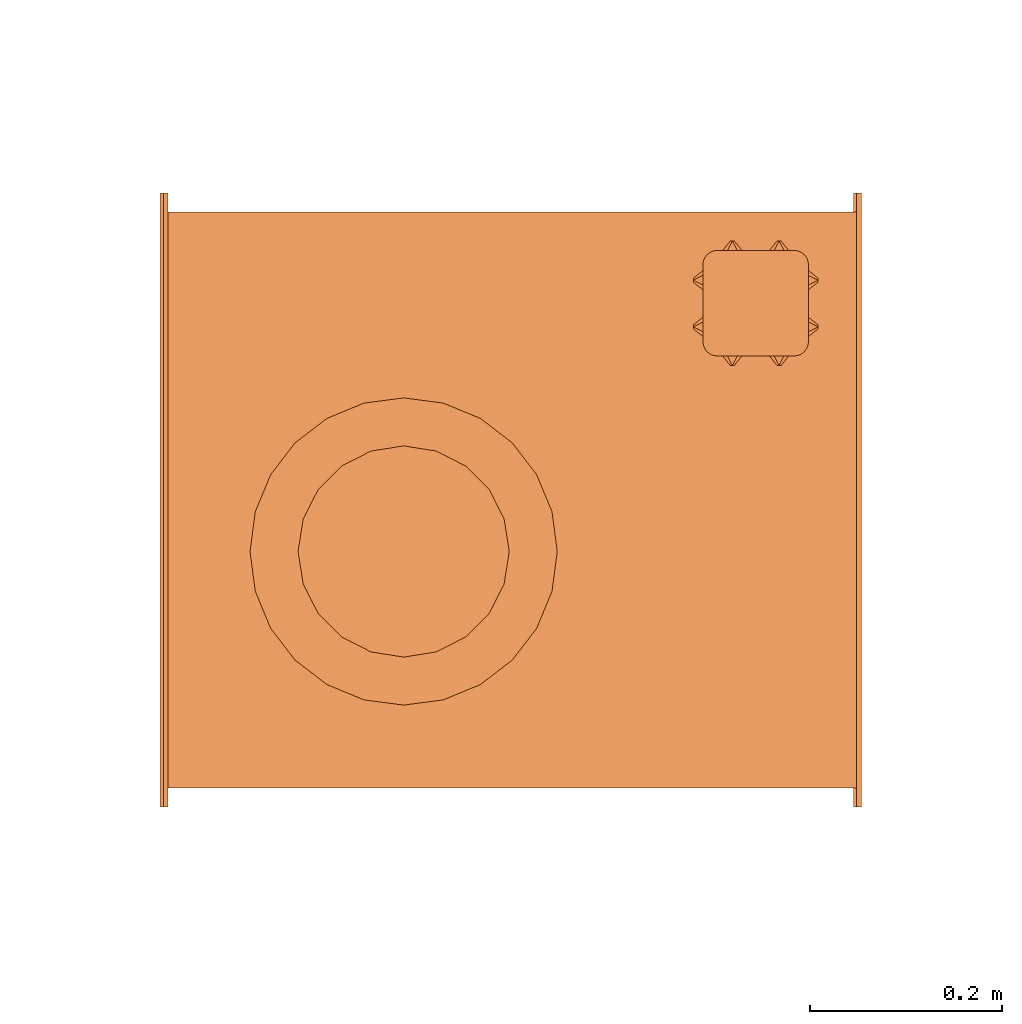
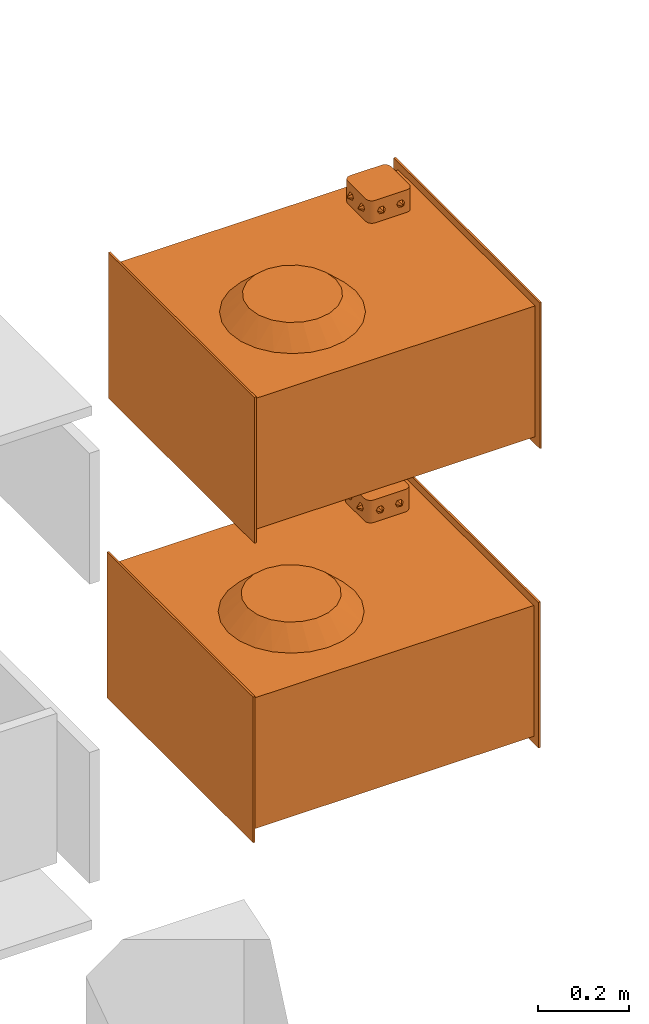
# One storey, part 44 of 44: 2 proxies.
"""IFC2X3 building model written with IfcOpenShell, lengths in millimetres."""

from ifc_helpers import new_model, entity, si_unit, converted_unit, derived_unit, direction, frame, origin, place, context, subcontext, project, spatial, faceted_brep, source, transform, mapped, material, material_list, type_object, type_shapes, element, save


model = new_model("IFC2X3")

# Units and contexts
model_context = context("Model", 3, precision=0.01, world=origin(), true_north=direction((6.12303176911189e-17, 1.0)))
body_context = subcontext(model_context, "Body", "Model", "MODEL_VIEW")
ifc_project = project(units=[si_unit("LENGTHUNIT", "METRE", prefix="MILLI"), si_unit("AREAUNIT", "SQUARE_METRE"), si_unit("VOLUMEUNIT", "CUBIC_METRE"), converted_unit("PLANEANGLEUNIT", "DEGREE", entity("IfcRatioMeasure", 0.0174532925199433), si_unit("PLANEANGLEUNIT", "RADIAN"), dimensions=[0, 0, 0, 0, 0, 0, 0]), si_unit("MASSUNIT", "GRAM", prefix="KILO"), derived_unit("MASSDENSITYUNIT", [(si_unit("MASSUNIT", "GRAM", prefix="KILO"), 1), (si_unit("LENGTHUNIT", "METRE"), -3)]), derived_unit("MOMENTOFINERTIAUNIT", [(si_unit("LENGTHUNIT", "METRE"), 4)]), si_unit("TIMEUNIT", "SECOND"), si_unit("FREQUENCYUNIT", "HERTZ"), si_unit("THERMODYNAMICTEMPERATUREUNIT", "DEGREE_CELSIUS"), derived_unit("THERMALTRANSMITTANCEUNIT", [(si_unit("MASSUNIT", "GRAM", prefix="KILO"), 1), (si_unit("THERMODYNAMICTEMPERATUREUNIT", "KELVIN"), -1), (si_unit("TIMEUNIT", "SECOND"), -3)]), derived_unit("VOLUMETRICFLOWRATEUNIT", [(si_unit("LENGTHUNIT", "METRE"), 3), (si_unit("TIMEUNIT", "SECOND"), -1)]), derived_unit("MASSFLOWRATEUNIT", [(si_unit("MASSUNIT", "GRAM", prefix="KILO"), 1), (si_unit("TIMEUNIT", "SECOND"), -1)]), derived_unit("ROTATIONALFREQUENCYUNIT", [(si_unit("TIMEUNIT", "SECOND"), -1)]), si_unit("ELECTRICCURRENTUNIT", "AMPERE"), si_unit("ELECTRICVOLTAGEUNIT", "VOLT"), si_unit("POWERUNIT", "WATT"), si_unit("FORCEUNIT", "NEWTON", prefix="KILO"), si_unit("ILLUMINANCEUNIT", "LUX"), si_unit("LUMINOUSFLUXUNIT", "LUMEN"), si_unit("LUMINOUSINTENSITYUNIT", "CANDELA"), derived_unit("USERDEFINED", [(si_unit("MASSUNIT", "GRAM", prefix="KILO"), -1), (si_unit("LENGTHUNIT", "METRE"), -2), (si_unit("TIMEUNIT", "SECOND"), 3), (si_unit("LUMINOUSFLUXUNIT", "LUMEN"), 1)]), derived_unit("LINEARVELOCITYUNIT", [(si_unit("LENGTHUNIT", "METRE"), 1), (si_unit("TIMEUNIT", "SECOND"), -1)]), si_unit("PRESSUREUNIT", "PASCAL"), derived_unit("USERDEFINED", [(si_unit("LENGTHUNIT", "METRE"), -2), (si_unit("MASSUNIT", "GRAM", prefix="KILO"), 1), (si_unit("TIMEUNIT", "SECOND"), -2)]), derived_unit("LINEARFORCEUNIT", [(si_unit("MASSUNIT", "GRAM", prefix="KILO"), 1), (si_unit("LENGTHUNIT", "METRE"), 1), (si_unit("TIMEUNIT", "SECOND"), -2), (si_unit("LENGTHUNIT", "METRE"), -1)]), derived_unit("PLANARFORCEUNIT", [(si_unit("MASSUNIT", "GRAM", prefix="KILO"), 1), (si_unit("LENGTHUNIT", "METRE"), 1), (si_unit("TIMEUNIT", "SECOND"), -2), (si_unit("LENGTHUNIT", "METRE"), -2)])], contexts=[model_context])

# Site, building, storey
site_placement = place(None, origin())
site = spatial("IfcSite", under=ifc_project, at=site_placement, CompositionType="ELEMENT")
building_placement = place(site_placement, origin())
building = spatial("IfcBuilding", under=site, at=building_placement, CompositionType="ELEMENT")
storey_placement = place(building_placement, frame((0.0, 0.0, 15900.0)))
storey = spatial("IfcBuildingStorey", under=building, at=storey_placement, CompositionType="ELEMENT", Elevation=15900.0)

# Proxies
ifc_material_1 = material()
ifc_material_2 = material()
ifc_material_list_1 = material_list([ifc_material_1, ifc_material_2])
ifc_material_3 = material()
ifc_material_list_2 = material_list([ifc_material_2, ifc_material_3, ifc_material_1])
building_element_proxy_type = type_object("IfcBuildingElementProxyType", PredefinedType="NOTDEFINED", material=ifc_material_list_2)
shared_shape = source(origin(), body_context, "Body", "Brep", [
    faceted_brep([(-188.5, -182.29, 203.93), (-188.5, -180.29, 201.93), (-188.5, -178.29, 203.93), (-188.5, -180.29, 205.93), (-198.5, -175.29, 195.27), (-198.5, -185.29, 195.27), (-198.5, -190.29, 203.93), (-198.5, -185.29, 212.59), (-198.5, -175.29, 212.59), (-198.5, -170.29, 203.93)], [[[0, 1, 2, 3]], [[4, 5, 6, 7, 8, 9]], [[2, 4, 9]], [[4, 2, 1]], [[1, 0, 5]], [[6, 5, 0]], [[1, 5, 4]], [[0, 7, 6]], [[7, 0, 3]], [[3, 2, 8]], [[9, 8, 2]], [[3, 8, 7]]]),
    faceted_brep([(-188.5, -226.95, 203.93), (-188.5, -228.95, 205.93), (-188.5, -230.95, 203.93), (-188.5, -228.95, 201.93), (-198.5, -223.95, 212.59), (-198.5, -218.95, 203.93), (-198.5, -223.95, 195.27), (-198.5, -233.95, 195.27), (-198.5, -238.95, 203.93), (-198.5, -233.95, 212.59)], [[[0, 1, 2, 3]], [[4, 5, 6, 7, 8, 9]], [[0, 6, 5]], [[6, 0, 3]], [[3, 2, 7]], [[8, 7, 2]], [[3, 7, 6]], [[2, 9, 8]], [[9, 2, 1]], [[1, 0, 4]], [[5, 4, 0]], [[1, 4, 9]]]),
    faceted_brep([(-318.5, -182.29, 203.93), (-318.5, -180.29, 205.93), (-318.5, -178.29, 203.93), (-318.5, -180.29, 201.93), (-308.5, -185.29, 212.59), (-308.5, -190.29, 203.93), (-308.5, -185.29, 195.27), (-308.5, -175.29, 195.27), (-308.5, -170.29, 203.93), (-308.5, -175.29, 212.59)], [[[0, 1, 2, 3]], [[4, 5, 6, 7, 8, 9]], [[0, 6, 5]], [[6, 0, 3]], [[3, 2, 7]], [[8, 7, 2]], [[3, 7, 6]], [[2, 9, 8]], [[9, 2, 1]], [[1, 0, 4]], [[5, 4, 0]], [[1, 4, 9]]]),
    faceted_brep([(-318.5, -226.95, 203.93), (-318.5, -228.95, 201.93), (-318.5, -230.95, 203.93), (-318.5, -228.95, 205.93), (-308.5, -233.95, 195.27), (-308.5, -223.95, 195.27), (-308.5, -218.95, 203.93), (-308.5, -223.95, 212.59), (-308.5, -233.95, 212.59), (-308.5, -238.95, 203.93)], [[[0, 1, 2, 3]], [[4, 5, 6, 7, 8, 9]], [[2, 4, 9]], [[4, 2, 1]], [[1, 0, 5]], [[6, 5, 0]], [[1, 5, 4]], [[0, 7, 6]], [[7, 0, 3]], [[3, 2, 8]], [[9, 8, 2]], [[3, 8, 7]]]),
    faceted_brep([(-231.17, -140.0, 203.93), (-229.17, -140.0, 205.93), (-227.17, -140.0, 203.93), (-229.17, -140.0, 201.93), (-234.17, -150.0, 212.59), (-239.17, -150.0, 203.93), (-234.17, -150.0, 195.27), (-224.17, -150.0, 195.27), (-219.17, -150.0, 203.93), (-224.17, -150.0, 212.59)], [[[0, 1, 2, 3]], [[4, 5, 6, 7, 8, 9]], [[0, 6, 5]], [[6, 0, 3]], [[3, 2, 7]], [[8, 7, 2]], [[3, 7, 6]], [[2, 9, 8]], [[9, 2, 1]], [[1, 0, 4]], [[5, 4, 0]], [[1, 4, 9]]]),
    faceted_brep([(-275.83, -140.0, 203.93), (-277.83, -140.0, 201.93), (-279.83, -140.0, 203.93), (-277.83, -140.0, 205.93), (-272.83, -150.0, 195.27), (-267.83, -150.0, 203.93), (-272.83, -150.0, 212.59), (-282.83, -150.0, 212.59), (-287.83, -150.0, 203.93), (-282.83, -150.0, 195.27)], [[[0, 1, 2, 3]], [[4, 5, 6, 7, 8, 9]], [[2, 9, 8]], [[9, 2, 1]], [[1, 0, 4]], [[5, 4, 0]], [[1, 4, 9]], [[0, 6, 5]], [[6, 0, 3]], [[3, 2, 7]], [[8, 7, 2]], [[3, 7, 6]]]),
    faceted_brep([(-231.17, -270.0, 203.93), (-229.17, -270.0, 201.93), (-227.17, -270.0, 203.93), (-229.17, -270.0, 205.93), (-234.17, -260.0, 195.27), (-239.17, -260.0, 203.93), (-234.17, -260.0, 212.59), (-224.17, -260.0, 212.59), (-219.17, -260.0, 203.93), (-224.17, -260.0, 195.27)], [[[0, 1, 2, 3]], [[4, 5, 6, 7, 8, 9]], [[2, 9, 8]], [[9, 2, 1]], [[1, 0, 4]], [[5, 4, 0]], [[1, 4, 9]], [[0, 6, 5]], [[6, 0, 3]], [[3, 2, 7]], [[8, 7, 2]], [[3, 7, 6]]]),
    faceted_brep([(-275.83, -270.0, 203.93), (-277.83, -270.0, 205.93), (-279.83, -270.0, 203.93), (-277.83, -270.0, 201.93), (-282.83, -260.0, 212.59), (-272.83, -260.0, 212.59), (-267.83, -260.0, 203.93), (-272.83, -260.0, 195.27), (-282.83, -260.0, 195.27), (-287.83, -260.0, 203.93)], [[[0, 1, 2, 3]], [[4, 5, 6, 7, 8, 9]], [[0, 7, 6]], [[7, 0, 3]], [[3, 2, 8]], [[9, 8, 2]], [[3, 8, 7]], [[2, 4, 9]], [[4, 2, 1]], [[1, 0, 5]], [[6, 5, 0]], [[1, 5, 4]]]),
    faceted_brep([(-213.5, -150.0, 235.0), (-293.5, -150.0, 235.0), (-297.38, -150.51, 235.0), (-301.0, -152.01, 235.0), (-304.11, -154.39, 235.0), (-306.49, -157.5, 235.0), (-307.99, -161.12, 235.0), (-308.5, -165.0, 235.0), (-308.5, -245.0, 235.0), (-307.99, -248.88, 235.0), (-306.49, -252.5, 235.0), (-304.11, -255.61, 235.0), (-301.0, -257.99, 235.0), (-297.38, -259.49, 235.0), (-293.5, -260.0, 235.0), (-213.5, -260.0, 235.0), (-209.62, -259.49, 235.0), (-206.0, -257.99, 235.0), (-202.89, -255.61, 235.0), (-200.51, -252.5, 235.0), (-199.01, -248.88, 235.0), (-198.5, -245.0, 235.0), (-198.5, -165.0, 235.0), (-199.01, -161.12, 235.0), (-200.51, -157.5, 235.0), (-202.89, -154.39, 235.0), (-206.0, -152.01, 235.0), (-209.62, -150.51, 235.0), (-297.38, -150.51, 175.0), (-293.5, -150.0, 175.0), (-213.5, -150.0, 175.0), (-209.62, -150.51, 175.0), (-206.0, -152.01, 175.0), (-202.89, -154.39, 175.0), (-200.51, -157.5, 175.0), (-199.01, -161.12, 175.0), (-198.5, -165.0, 175.0), (-198.5, -245.0, 175.0), (-199.01, -248.88, 175.0), (-200.51, -252.5, 175.0), (-202.89, -255.61, 175.0), (-206.0, -257.99, 175.0), (-209.62, -259.49, 175.0), (-213.5, -260.0, 175.0), (-293.5, -260.0, 175.0), (-297.38, -259.49, 175.0), (-301.0, -257.99, 175.0), (-304.11, -255.61, 175.0), (-306.49, -252.5, 175.0), (-307.99, -248.88, 175.0), (-308.5, -245.0, 175.0), (-308.5, -165.0, 175.0), (-307.99, -161.12, 175.0), (-306.49, -157.5, 175.0), (-304.11, -154.39, 175.0), (-301.0, -152.01, 175.0)], [[[0, 1, 2, 3, 4, 5, 6, 7, 8, 9, 10, 11, 12, 13, 14, 15, 16, 17, 18, 19, 20, 21, 22, 23, 24, 25, 26, 27]], [[28, 29, 30, 31, 32, 33, 34, 35, 36, 37, 38, 39, 40, 41, 42, 43, 44, 45, 46, 47, 48, 49, 50, 51, 52, 53, 54, 55]], [[1, 0, 30, 29]], [[2, 28, 55, 3]], [[3, 55, 54, 4]], [[29, 28, 2, 1]], [[5, 53, 52, 6]], [[6, 52, 51, 7]], [[4, 54, 53, 5]], [[8, 7, 51, 50]], [[9, 49, 48, 10]], [[10, 48, 47, 11]], [[50, 49, 9, 8]], [[12, 46, 45, 13]], [[13, 45, 44, 14]], [[11, 47, 46, 12]], [[15, 14, 44, 43]], [[16, 42, 41, 17]], [[17, 41, 40, 18]], [[43, 42, 16, 15]], [[19, 39, 38, 20]], [[20, 38, 37, 21]], [[18, 40, 39, 19]], [[22, 21, 37, 36]], [[23, 35, 34, 24]], [[24, 34, 33, 25]], [[36, 35, 23, 22]], [[26, 32, 31, 27]], [[27, 31, 30, 0]], [[25, 33, 32, 26]]]),
    faceted_brep([(363.5, -320.0, 195.0), (363.5, -320.0, -195.0), (363.5, 320.0, -195.0), (363.5, 320.0, 195.0), (358.5, -320.0, 195.0), (358.5, 320.0, 195.0), (358.5, 320.0, -195.0), (358.5, -320.0, -195.0)], [[[0, 1, 2, 3]], [[4, 5, 6, 7]], [[1, 0, 4, 7]], [[2, 1, 7, 6]], [[3, 2, 6, 5]], [[0, 3, 5, 4]]]),
    faceted_brep([(-358.5, -320.0, 195.0), (-358.5, -320.0, -195.0), (-358.5, 320.0, -195.0), (-358.5, 320.0, 195.0), (-363.5, -320.0, 195.0), (-363.5, 320.0, 195.0), (-363.5, 320.0, -195.0), (-363.5, -320.0, -195.0)], [[[0, 1, 2, 3]], [[4, 5, 6, 7]], [[1, 0, 4, 7]], [[2, 1, 7, 6]], [[3, 2, 6, 5]], [[0, 3, 5, 4]]]),
    faceted_brep([(358.5, -300.0, 175.0), (358.5, -300.0, -175.0), (358.5, 300.0, -175.0), (358.5, 300.0, 175.0), (-358.5, -300.0, 175.0), (-358.5, 300.0, 175.0), (-358.5, 300.0, -175.0), (-358.5, -300.0, -175.0)], [[[0, 1, 2, 3]], [[4, 5, 6, 7]], [[1, 0, 4, 7]], [[2, 1, 7, 6]], [[3, 2, 6, 5]], [[0, 3, 5, 4]]]),
    faceted_brep([(223.22, 53.64, 223.0), (217.84, 87.63, 223.0), (202.22, 118.29, 223.0), (177.88, 142.63, 223.0), (147.22, 158.25, 223.0), (113.22, 163.64, 223.0), (79.23, 158.25, 223.0), (48.57, 142.63, 223.0), (24.23, 118.29, 223.0), (8.61, 87.63, 223.0), (3.22, 53.64, 223.0), (8.61, 19.65, 223.0), (24.23, -11.02, 223.0), (48.57, -35.35, 223.0), (79.23, -50.98, 223.0), (113.22, -56.36, 223.0), (147.22, -50.98, 223.0), (177.88, -35.35, 223.0), (202.22, -11.02, 223.0), (217.84, 19.65, 223.0), (273.22, 53.64, 175.0), (267.77, 12.23, 175.0), (251.79, -26.36, 175.0), (226.36, -59.5, 175.0), (193.22, -84.93, 175.0), (154.64, -100.91, 175.0), (113.22, -106.36, 175.0), (71.81, -100.91, 175.0), (33.22, -84.93, 175.0), (0.09, -59.5, 175.0), (-25.34, -26.36, 175.0), (-41.32, 12.23, 175.0), (-46.78, 53.64, 175.0), (-41.32, 95.05, 175.0), (-25.34, 133.64, 175.0), (0.09, 166.77, 175.0), (33.22, 192.2, 175.0), (71.81, 208.19, 175.0), (113.22, 213.64, 175.0), (154.64, 208.19, 175.0), (193.22, 192.2, 175.0), (226.36, 166.77, 175.0), (251.79, 133.64, 175.0), (267.77, 95.05, 175.0)], [[[0, 1, 2, 3, 4, 5, 6, 7, 8, 9, 10, 11, 12, 13, 14, 15, 16, 17, 18, 19]], [[20, 21, 22, 23, 24, 25, 26, 27, 28, 29, 30, 31, 32, 33, 34, 35, 36, 37, 38, 39, 40, 41, 42, 43]], [[14, 13, 28]], [[15, 14, 27]], [[11, 10, 31]], [[12, 11, 30]], [[13, 12, 29]], [[14, 28, 27]], [[27, 26, 15]], [[13, 29, 28]], [[12, 30, 29]], [[30, 11, 31]], [[10, 32, 31]], [[32, 10, 33]], [[33, 10, 9]], [[8, 34, 9]], [[36, 7, 6]], [[35, 8, 7]], [[37, 6, 5]], [[9, 34, 33]], [[8, 35, 34]], [[36, 35, 7]], [[6, 37, 36]], [[5, 38, 37]], [[4, 3, 40]], [[5, 4, 39]], [[1, 0, 43]], [[2, 1, 42]], [[3, 2, 41]], [[4, 40, 39]], [[39, 38, 5]], [[3, 41, 40]], [[2, 42, 41]], [[42, 1, 43]], [[0, 20, 43]], [[20, 0, 21]], [[21, 0, 19]], [[18, 22, 19]], [[24, 17, 16]], [[23, 18, 17]], [[25, 16, 15]], [[19, 22, 21]], [[18, 23, 22]], [[24, 23, 17]], [[16, 25, 24]], [[15, 26, 25]]]),
])
type_shapes(building_element_proxy_type, [shared_shape])
for number, where, z_axis, x_axis in (
    (1, (26938.1, 12964.59, 13575.0), (0.0, 0.0, 1.0), (-1.0, 0.0, 0.0)),
    (2, (26934.8, 12964.59, 12775.0), (0.0, 0.0, 1.0), (-1.0, 0.0, 0.0)),
):
    element("IfcBuildingElementProxy", number, at=place(storey_placement, frame(where, z_axis=z_axis, x_axis=x_axis)), inside=storey, type_object=building_element_proxy_type, material=ifc_material_list_1, context=body_context, shape_type="MappedRepresentation", body=[
        mapped(shared_shape, transform((0.0, 0.0, 0.0), scale=1.0)),
    ])

save(model, "model.ifc")
